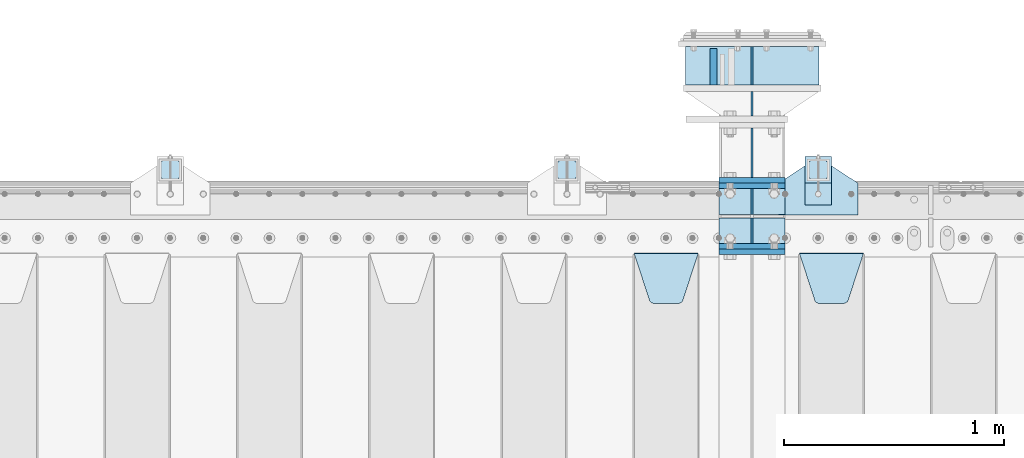
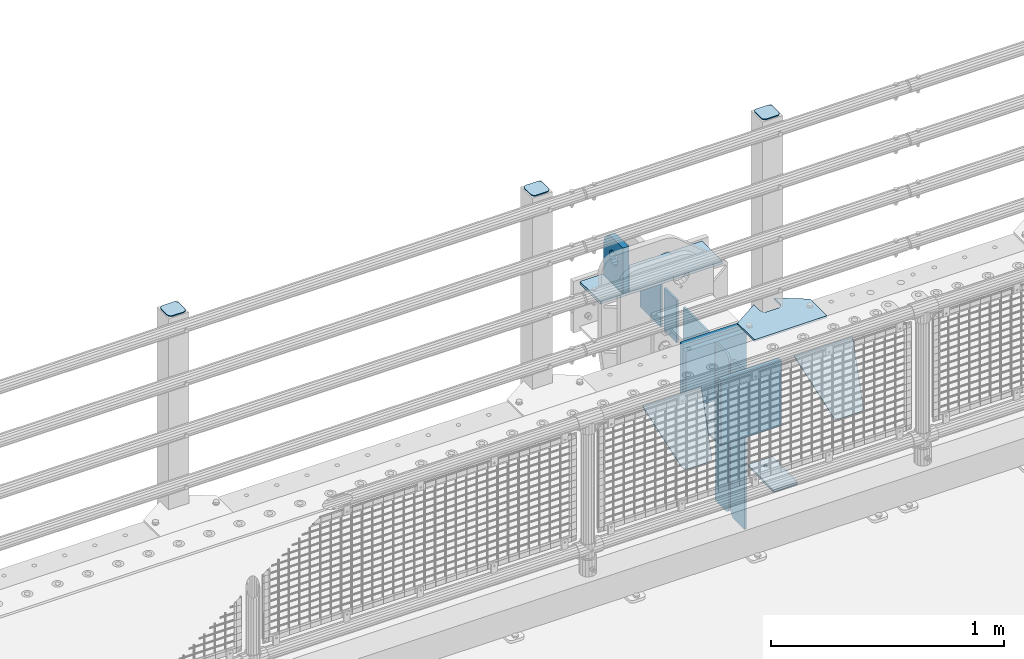
# One storey, part 200 of 219: 23 plates.
"""IFC2X3 building model written with IfcOpenShell, lengths in millimetres."""

from ifc_helpers import new_model, si_unit, frame, origin_with_axes, place, context, subcontext, project, spatial, faceted_brep, material, type_object, element, save


model = new_model("IFC2X3")

# Units and contexts
model_context = context("Model", 3, precision=1e-05, world=origin_with_axes())
body_context = subcontext(model_context, "Body", "Model", "MODEL_VIEW")
ifc_project = project(units=[si_unit("LENGTHUNIT", "METRE", prefix="MILLI"), si_unit("AREAUNIT", "SQUARE_METRE"), si_unit("VOLUMEUNIT", "CUBIC_METRE"), si_unit("MASSUNIT", "GRAM", prefix="KILO"), si_unit("TIMEUNIT", "SECOND"), si_unit("PLANEANGLEUNIT", "RADIAN"), si_unit("SOLIDANGLEUNIT", "STERADIAN"), si_unit("THERMODYNAMICTEMPERATUREUNIT", "DEGREE_CELSIUS"), si_unit("LUMINOUSINTENSITYUNIT", "LUMEN")], contexts=[model_context])

# Site, building, storey
site_placement = place(None, origin_with_axes())
site = spatial("IfcSite", under=ifc_project, at=site_placement, CompositionType="ELEMENT")
building_placement = place(site_placement, origin_with_axes())
building = spatial("IfcBuilding", under=site, at=building_placement, Name="Standard", CompositionType="ELEMENT")
storey_placement = place(building_placement, origin_with_axes())
storey = spatial("IfcBuildingStorey", under=building, at=storey_placement, Name="Undefined", CompositionType="ELEMENT", Elevation=0.0)

# Plates
ifc_material_1 = material(Name="STEEL/S355N")
plate_type_1 = type_object("IfcPlateType", PredefinedType="NOTDEFINED")
plate_1_placement = place(storey_placement, frame((10239.9999999781, 33162.4999999848, -340.000018238371), z_axis=(0.0, 0.0, 1.0), x_axis=(1.0, 0.0, 0.0)))
element("IfcPlate", 1, at=plate_1_placement, inside=storey, type_object=plate_type_1, material=ifc_material_1, context=body_context, shape_type="Brep", body=[
    faceted_brep([(0.0, -12.5, 0.0), (0.0, -12.5, 330.0), (0.0, 12.5, 330.0), (0.0, 12.5, 0.0), (300.0, -12.5, 330.0), (300.0, 12.5, 330.0), (300.0, -12.5, 0.0), (300.0, 12.5, 0.0)], [[[0, 1, 2, 3]], [[1, 4, 5, 2]], [[4, 6, 7, 5]], [[6, 0, 3, 7]], [[5, 7, 3, 2]], [[6, 4, 1, 0]]]),
])
plate_2_placement = place(storey_placement, frame((10240.0, 32837.5, -340.000000000044), z_axis=(0.0, 0.0, 1.0), x_axis=(1.0, 0.0, 0.0)))
element("IfcPlate", 2, at=plate_2_placement, inside=storey, type_object=plate_type_1, material=ifc_material_1, context=body_context, shape_type="Brep", body=[
    faceted_brep([(0.0, -12.5, 0.0), (9.27684595808387e-10, -12.5, 340.0), (9.27684595808387e-10, 12.5, 340.0), (0.0, 12.5, 0.0), (300.0, -12.5, 340.0), (300.0, 12.5, 340.0), (300.0, -12.5, 0.0), (300.0, 12.5, 0.0)], [[[0, 1, 2, 3]], [[1, 4, 5, 2]], [[4, 6, 7, 5]], [[6, 0, 3, 7]], [[5, 7, 3, 2]], [[6, 4, 1, 0]]]),
])
for number, where, z_axis, x_axis in (
    (3, (10240.0, 33137.5, -340.0), (0.0, 0.0, 1.0), (1.0, 0.0, 0.0)),
    (4, (10240.0, 32862.5, -340.0), (0.0, 0.0, 1.0), (1.0, 0.0, 0.0)),
):
    element("IfcPlate", number, at=place(storey_placement, frame(where, z_axis=z_axis, x_axis=x_axis)), inside=storey, type_object=plate_type_1, material=ifc_material_1, context=body_context, shape_type="Brep", body=[
        faceted_brep([(0.0, -12.5, 0.0), (0.0, -12.5, 310.0), (0.0, 12.5, 310.0), (0.0, 12.5, 0.0), (300.0, -12.5, 310.0), (300.0, 12.5, 310.0), (300.0, -12.5, 0.0), (300.0, 12.5, 0.0)], [[[0, 1, 2, 3]], [[1, 4, 5, 2]], [[4, 6, 7, 5]], [[6, 0, 3, 7]], [[5, 7, 3, 2]], [[6, 4, 1, 0]]]),
    ])
plate_type_2 = type_object("IfcPlateType", PredefinedType="NOTDEFINED")
plate_3_placement = place(storey_placement, frame((10389.9999999781, 33174.9999999848, -336.000018238371), z_axis=(0.0, 1.0, 0.0), x_axis=(0.0, 0.0, 1.0)))
element("IfcPlate", 5, at=plate_3_placement, inside=storey, type_object=plate_type_2, material=ifc_material_1, context=body_context, shape_type="Brep", body=[
    faceted_brep([(0.0, -5.0, 0.0), (100.0, -5.0, 225.0), (100.0, 5.0, 225.0), (0.0, 5.0, 0.0), (322.0, -5.0, 225.0), (322.0, 5.0, 225.0), (322.0, -5.0, 0.0), (322.0, 5.0, 0.0)], [[[0, 1, 2, 3]], [[1, 4, 5, 2]], [[4, 6, 7, 5]], [[6, 0, 3, 7]], [[5, 7, 3, 2]], [[6, 4, 1, 0]]]),
])
plate_type_3 = type_object("IfcPlateType", PredefinedType="NOTDEFINED")
plate_4_placement = place(storey_placement, frame((10214.4999999781, 33594.9999999848, -1.82383710125578e-05), z_axis=(0.0, 1.0, 0.0), x_axis=(0.0, 0.0, 1.0)))
element("IfcPlate", 6, at=plate_4_placement, inside=storey, type_object=plate_type_3, material=ifc_material_1, context=body_context, shape_type="Brep", body=[
    faceted_brep([(125.840713002492, 15.0, 114.183542702915), (125.840713002492, -15.0, 114.183542702915), (113.837049096098, -15.0, 106.162950903905), (113.837049096098, 15.0, 106.162950903905), (105.816457297082, -15.0, 94.1592869975066), (105.816457297082, 15.0, 94.1592869975066), (103.0, -15.0, 80.0), (103.0, 15.0, 80.0), (105.816457297082, -15.0, 65.8407130024934), (105.816457297082, 15.0, 65.8407130024934), (113.837049096098, -15.0, 53.8370490960951), (113.837049096098, 15.0, 53.8370490960951), (125.840713002492, -15.0, 45.8164572970854), (125.840713002492, 15.0, 45.8164572970854), (140.0, -15.0, 43.0), (140.0, 15.0, 43.0), (154.159286997508, -15.0, 45.8164572970854), (154.159286997508, 15.0, 45.8164572970854), (166.162950903902, -15.0, 53.8370490960951), (166.162950903902, 15.0, 53.8370490960951), (174.183542702918, -15.0, 65.8407130024934), (174.183542702918, 15.0, 65.8407130024934), (177.0, -15.0, 80.0), (177.0, 15.0, 80.0), (174.183542702918, -15.0, 94.1592869975066), (174.183542702918, 15.0, 94.1592869975066), (166.162950903902, -15.0, 106.162950903905), (166.162950903902, 15.0, 106.162950903905), (154.159286997508, -15.0, 114.183542702915), (154.159286997508, 15.0, 114.183542702915), (140.0, -15.0, 117.0), (140.0, 15.0, 117.0), (0.0, -15.0, 165.0), (170.0, -15.0, 165.0), (170.0, 15.0, 165.0), (0.0, 15.0, 165.0), (188.117333157176, -15.0, 162.614807840233), (188.117333157176, 15.0, 162.614807840233), (205.0, -15.0, 155.621778264911), (205.0, 15.0, 155.621778264911), (219.497474683058, -15.0, 144.497474683056), (219.497474683058, 15.0, 144.497474683056), (230.621778264911, -15.0, 130.0), (230.621778264911, 15.0, 130.0), (237.614807840235, -15.0, 113.117333157177), (237.614807840235, 15.0, 113.117333157177), (240.0, -15.0, 95.0), (240.0, 15.0, 95.0), (240.0, -15.0, 0.0), (240.0, 15.0, 0.0), (0.0, -15.0, 0.0), (0.0, 15.0, 0.0)], [[[0, 1, 2, 3]], [[3, 2, 4, 5]], [[5, 4, 6, 7]], [[7, 6, 8, 9]], [[9, 8, 10, 11]], [[11, 10, 12, 13]], [[13, 12, 14, 15]], [[15, 14, 16, 17]], [[17, 16, 18, 19]], [[19, 18, 20, 21]], [[21, 20, 22, 23]], [[23, 22, 24, 25]], [[25, 24, 26, 27]], [[27, 26, 28, 29]], [[29, 28, 30, 31]], [[31, 30, 1, 0]], [[32, 33, 34, 35]], [[33, 36, 37, 34]], [[36, 38, 39, 37]], [[38, 40, 41, 39]], [[40, 42, 43, 41]], [[42, 44, 45, 43]], [[44, 46, 47, 45]], [[46, 48, 49, 47]], [[48, 50, 51, 49]], [[34, 37, 39, 41, 43, 45, 47, 49, 51, 35], [3, 5, 7, 9, 11, 13, 15, 17, 19, 21, 23, 25, 27, 29, 31, 0]], [[50, 32, 35, 51]], [[48, 46, 44, 42, 40, 38, 36, 33, 32, 50], [26, 24, 22, 20, 18, 16, 14, 12, 10, 8, 6, 4, 2, 1, 30, 28]]]),
])
plate_type_4 = type_object("IfcPlateType", PredefinedType="NOTDEFINED")
for number, where, z_axis, x_axis in (
    (7, (10240.0, 32992.0, -343.0), (0.0, -1.0, 0.0), (1.0, 0.0, 0.0)),
    (8, (10240.0, 33008.0, -343.0), (0.0, 1.0, 0.0), (1.0, 0.0, 0.0)),
):
    element("IfcPlate", number, at=place(storey_placement, frame(where, z_axis=z_axis, x_axis=x_axis)), inside=storey, type_object=plate_type_4, material=ifc_material_1, context=body_context, shape_type="Brep", body=[
        faceted_brep([(0.0, -7.0, 0.0), (0.0, -7.0, 117.0), (0.0, 7.0, 117.0), (0.0, 7.0, 0.0), (300.0, -7.0, 117.0), (300.0, 7.0, 117.0), (300.0, -7.0, 0.0), (300.0, 7.0, 0.0)], [[[0, 1, 2, 3]], [[1, 4, 5, 2]], [[4, 6, 7, 5]], [[6, 0, 3, 7]], [[5, 7, 3, 2]], [[6, 4, 1, 0]]]),
    ])
plate_type_5 = type_object("IfcPlateType", PredefinedType="NOTDEFINED")
for number, where, z_axis, x_axis in (
    (9, (10390.0, 33008.0, -30.0), (0.0, 0.0, -1.0), (0.0, 1.0, 0.0)),
    (10, (10390.0, 32992.0, -30.0), (0.0, 0.0, -1.0), (0.0, -1.0, 0.0)),
):
    element("IfcPlate", number, at=place(storey_placement, frame(where, z_axis=z_axis, x_axis=x_axis)), inside=storey, type_object=plate_type_5, material=ifc_material_1, context=body_context, shape_type="Brep", body=[
        faceted_brep([(0.0, -5.0, 30.0), (0.0, -5.0, 306.0), (0.0, 5.0, 306.0), (0.0, 5.0, 30.0), (117.0, -5.0, 306.0), (117.0, 5.0, 306.0), (117.0, -5.0, 0.0), (117.0, 5.0, 0.0), (30.0, -5.0, 0.0), (30.0, 5.0, 0.0), (24.7905546699913, -5.0, 0.455767409633758), (24.7905546699913, 5.0, 0.455767409633758), (19.7393957002278, -5.0, 1.80922137642275), (19.7393957002278, 5.0, 1.80922137642275), (15.0, -5.0, 4.01923788646684), (15.0, 5.0, 4.01923788646684), (10.7163717094008, -5.0, 7.01866670643066), (10.7163717094008, 5.0, 7.01866670643066), (7.01866670643358, -5.0, 10.7163717094038), (7.01866670643358, 5.0, 10.7163717094038), (4.01923788646673, -5.0, 15.0), (4.01923788646673, 5.0, 15.0), (1.80922137642483, -5.0, 19.7393957002299), (1.80922137642483, 5.0, 19.7393957002299), (0.455767409635882, -5.0, 24.7905546699921), (0.455767409635882, 5.0, 24.7905546699921)], [[[0, 1, 2, 3]], [[1, 4, 5, 2]], [[4, 6, 7, 5]], [[6, 8, 9, 7]], [[8, 10, 11, 9]], [[10, 12, 13, 11]], [[12, 14, 15, 13]], [[14, 16, 17, 15]], [[16, 18, 19, 17]], [[18, 20, 21, 19]], [[20, 22, 23, 21]], [[22, 24, 25, 23]], [[24, 0, 3, 25]], [[5, 7, 9, 11, 13, 15, 17, 19, 21, 23, 25, 3, 2]], [[24, 22, 20, 18, 16, 14, 12, 10, 8, 6, 4, 1, 0]]]),
    ])
for number, where, z_axis, x_axis in (
    (11, (10390.0, 32992.0, -350.0), (0.0, 0.0, -1.0), (0.0, -1.0, 0.0)),
    (12, (10390.0, 33008.0, -350.0), (0.0, 0.0, -1.0), (0.0, 1.0, 0.0)),
):
    element("IfcPlate", number, at=place(storey_placement, frame(where, z_axis=z_axis, x_axis=x_axis)), inside=storey, type_object=plate_type_5, material=ifc_material_1, context=body_context, shape_type="Brep", body=[
        faceted_brep([(0.0, -5.0, 0.0), (0.0, -5.0, 480.0), (0.0, 5.0, 480.0), (0.0, 5.0, 0.0), (0.455767409635882, -5.0, 485.209445330008), (0.455767409635882, 5.0, 485.209445330008), (1.80922137642483, -5.0, 490.26060429977), (1.80922137642483, 5.0, 490.26060429977), (4.01923788646673, -5.0, 495.0), (4.01923788646673, 5.0, 495.0), (7.01866670643358, -5.0, 499.283628290596), (7.01866670643358, 5.0, 499.283628290596), (10.7163717094008, -5.0, 502.981333293569), (10.7163717094008, 5.0, 502.981333293569), (15.0, -5.0, 505.980762113533), (15.0, 5.0, 505.980762113533), (19.7393957002278, -5.0, 508.190778623577), (19.7393957002278, 5.0, 508.190778623577), (24.7905546699913, -5.0, 509.544232590366), (24.7905546699913, 5.0, 509.544232590366), (30.0, -5.0, 510.0), (30.0, 5.0, 510.0), (117.0, -5.0, 510.0), (117.0, 5.0, 510.0), (117.0, -5.0, 0.0), (117.0, 5.0, 0.0)], [[[0, 1, 2, 3]], [[1, 4, 5, 2]], [[4, 6, 7, 5]], [[6, 8, 9, 7]], [[8, 10, 11, 9]], [[10, 12, 13, 11]], [[12, 14, 15, 13]], [[14, 16, 17, 15]], [[16, 18, 19, 17]], [[18, 20, 21, 19]], [[20, 22, 23, 21]], [[22, 24, 25, 23]], [[24, 0, 3, 25]], [[5, 7, 9, 11, 13, 15, 17, 19, 21, 23, 25, 3, 2]], [[24, 22, 20, 18, 16, 14, 12, 10, 8, 6, 4, 1, 0]]]),
    ])
plate_type_6 = type_object("IfcPlateType", PredefinedType="NOTDEFINED")
plate_5_placement = place(storey_placement, frame((10605.0, 32831.767766956, -1.76776695296758), z_axis=(0.0, -0.707106781186547, -0.707106781186548), x_axis=(1.0, 0.0, 0.0)))
element("IfcPlate", 13, at=plate_5_placement, inside=storey, type_object=plate_type_6, material=ifc_material_1, context=body_context, shape_type="Brep", body=[
    faceted_brep([(0.0, -2.5, 0.0), (69.345504679477, -2.5, 300.171731424834), (69.345504679477, 2.49999999999636, 300.171731424831), (0.0, 2.5, 0.0), (70.9274061199576, -2.50000000000364, 304.8974424154), (70.9274061199576, 2.49999999999636, 304.8974424154), (73.3818627772307, -2.50000000000364, 309.234538108532), (73.3818627772307, 2.49999999999636, 309.234538108532), (76.6187032999569, -2.50000000000364, 313.023683126106), (76.6187032999569, 2.49999999999636, 313.023683126106), (80.5190132704993, -2.50000000000364, 316.125672595372), (80.5190132704993, 2.49999999999636, 316.125672595372), (84.9395038596831, -2.50000000000364, 318.426546230476), (84.9395038596831, 2.5, 318.426546230479), (89.7177759439237, -2.50000000000364, 319.841774983277), (89.7177759439237, 2.5, 319.841774983281), (94.6782862926502, -2.50000000000364, 320.319366455078), (94.6782862926502, 2.49999999999636, 320.319366455078), (195.32171370735, -2.50000000000364, 320.319366455078), (195.32171370735, 2.49999999999636, 320.319366455078), (200.282224056076, -2.50000000000364, 319.841774983277), (200.282224056076, 2.5, 319.841774983281), (205.060496140317, -2.50000000000364, 318.426546230476), (205.060496140317, 2.49999999999636, 318.426546230476), (209.480986729501, -2.50000000000364, 316.125672595372), (209.480986729501, 2.49999999999636, 316.125672595372), (213.381296700043, -2.50000000000364, 313.023683126106), (213.381296700043, 2.49999999999272, 313.023683126106), (216.618137222769, -2.50000000000364, 309.234538108529), (216.618137222769, 2.49999999999636, 309.234538108525), (219.072593880042, -2.50000000000364, 304.8974424154), (219.072593880042, 2.49999999999636, 304.8974424154), (220.654495320523, -2.5, 300.171731424834), (220.654495320523, 2.49999999999636, 300.171731424831), (290.0, -2.50000000000364, 3.63797880709171e-12), (290.0, 2.49999999999636, 0.0)], [[[0, 1, 2, 3]], [[1, 4, 5, 2]], [[4, 6, 7, 5]], [[6, 8, 9, 7]], [[8, 10, 11, 9]], [[10, 12, 13, 11]], [[12, 14, 15, 13]], [[14, 16, 17, 15]], [[16, 18, 19, 17]], [[18, 20, 21, 19]], [[20, 22, 23, 21]], [[22, 24, 25, 23]], [[24, 26, 27, 25]], [[26, 28, 29, 27]], [[28, 30, 31, 29]], [[30, 32, 33, 31]], [[32, 34, 35, 33]], [[34, 0, 3, 35]], [[5, 7, 9, 11, 13, 15, 17, 19, 21, 23, 25, 27, 29, 31, 33, 35, 3, 2]], [[34, 32, 30, 28, 26, 24, 22, 20, 18, 16, 14, 12, 10, 8, 6, 4, 1, 0]]]),
])
plate_6_placement = place(storey_placement, frame((9855.0, 32831.767766956, -1.76776695296758), z_axis=(0.0, -0.707106781186547, -0.707106781186548), x_axis=(1.0, 0.0, 0.0)))
element("IfcPlate", 14, at=plate_6_placement, inside=storey, type_object=plate_type_6, material=ifc_material_1, context=body_context, shape_type="Brep", body=[
    faceted_brep([(0.0, -2.5, 0.0), (69.345504679477, -2.5, 300.171731424834), (69.345504679477, 2.49999999999636, 300.171731424831), (0.0, 2.5, 0.0), (70.9274061199576, -2.50000000000364, 304.8974424154), (70.9274061199576, 2.49999999999636, 304.8974424154), (73.3818627772307, -2.50000000000364, 309.234538108532), (73.3818627772307, 2.49999999999636, 309.234538108532), (76.6187032999569, -2.50000000000364, 313.023683126106), (76.6187032999569, 2.49999999999636, 313.023683126106), (80.5190132704993, -2.50000000000364, 316.125672595372), (80.5190132704993, 2.49999999999636, 316.125672595372), (84.9395038596831, -2.50000000000364, 318.426546230476), (84.9395038596831, 2.5, 318.426546230479), (89.7177759439237, -2.50000000000364, 319.841774983277), (89.7177759439237, 2.5, 319.841774983281), (94.6782862926502, -2.50000000000364, 320.319366455078), (94.6782862926502, 2.49999999999636, 320.319366455078), (195.32171370735, -2.50000000000364, 320.319366455078), (195.32171370735, 2.49999999999636, 320.319366455078), (200.282224056076, -2.50000000000364, 319.841774983277), (200.282224056076, 2.5, 319.841774983281), (205.060496140317, -2.50000000000364, 318.426546230476), (205.060496140317, 2.49999999999636, 318.426546230476), (209.480986729501, -2.50000000000364, 316.125672595372), (209.480986729501, 2.49999999999636, 316.125672595372), (213.381296700043, -2.50000000000364, 313.023683126106), (213.381296700043, 2.49999999999272, 313.023683126106), (216.618137222769, -2.50000000000364, 309.234538108529), (216.618137222769, 2.49999999999636, 309.234538108525), (219.072593880042, -2.50000000000364, 304.8974424154), (219.072593880042, 2.49999999999636, 304.8974424154), (220.654495320523, -2.5, 300.171731424834), (220.654495320523, 2.49999999999636, 300.171731424831), (290.0, -2.50000000000364, 3.63797880709171e-12), (290.0, 2.49999999999636, 0.0)], [[[0, 1, 2, 3]], [[1, 4, 5, 2]], [[4, 6, 7, 5]], [[6, 8, 9, 7]], [[8, 10, 11, 9]], [[10, 12, 13, 11]], [[12, 14, 15, 13]], [[14, 16, 17, 15]], [[16, 18, 19, 17]], [[18, 20, 21, 19]], [[20, 22, 23, 21]], [[22, 24, 25, 23]], [[24, 26, 27, 25]], [[26, 28, 29, 27]], [[28, 30, 31, 29]], [[30, 32, 33, 31]], [[32, 34, 35, 33]], [[34, 0, 3, 35]], [[5, 7, 9, 11, 13, 15, 17, 19, 21, 23, 25, 27, 29, 31, 33, 35, 3, 2]], [[34, 32, 30, 28, 26, 24, 22, 20, 18, 16, 14, 12, 10, 8, 6, 4, 1, 0]]]),
])
ifc_material_2 = material(Name="STEEL/S355J2")
plate_type_7 = type_object("IfcPlateType", PredefinedType="NOTDEFINED")
plate_7_placement = place(storey_placement, frame((10510.0, 33005.0, 5.00000000004911), z_axis=(0.0, 1.0, 0.0), x_axis=(1.0, 0.0, 0.0)))
element("IfcPlate", 15, at=plate_7_placement, inside=storey, type_object=plate_type_7, material=ifc_material_2, context=body_context, shape_type="Brep", body=[
    faceted_brep([(0.0, -5.0, 0.0), (2.31396552408114e-06, -5.0, 145.0), (2.31396552408114e-06, 5.0, 145.0), (0.0, 5.0, 0.0), (130.0, -5.0, 230.0), (130.0, 5.0, 230.0), (130.0, -5.0, 180.0), (130.0, 5.0, 180.0), (130.48036798992, -5.0, 175.122741949599), (130.48036798992, 5.0, 175.122741949599), (131.903011687218, -5.0, 170.432914190875), (131.903011687218, 5.0, 170.432914190875), (134.213259692437, -5.0, 166.110744174512), (134.213259692437, 5.0, 166.110744174512), (137.322330470337, -5.0, 162.322330470335), (137.322330470337, 5.0, 162.322330470335), (141.11074417451, -5.0, 159.213259692435), (141.11074417451, 5.0, 159.213259692435), (145.432914190873, -5.0, 156.903011687216), (145.432914190873, 5.0, 156.903011687216), (150.122741949597, -5.0, 155.48036798992), (150.122741949597, 5.0, 155.48036798992), (155.0, -5.0, 155.0), (155.0, 5.0, 155.0), (205.0, -5.0, 155.0), (205.0, 5.0, 155.0), (209.877258050403, -5.0, 155.48036798992), (209.877258050403, 5.0, 155.48036798992), (214.567085809127, -5.0, 156.903011687216), (214.567085809127, 5.0, 156.903011687216), (218.88925582549, -5.0, 159.213259692435), (218.88925582549, 5.0, 159.213259692435), (222.677669529663, -5.0, 162.322330470335), (222.677669529663, 5.0, 162.322330470335), (225.786740307563, -5.0, 166.110744174512), (225.786740307563, 5.0, 166.110744174512), (228.096988312782, -5.0, 170.432914190875), (228.096988312782, 5.0, 170.432914190875), (229.51963201008, -5.0, 175.122741949599), (229.51963201008, 5.0, 175.122741949599), (230.0, -5.0, 180.0), (230.0, 5.0, 180.0), (230.0, -5.0, 230.0), (230.0, 5.0, 230.0), (360.0, -5.0, 145.0), (360.0, 5.0, 145.0), (360.0, -5.0, -7.27595761418343e-12), (360.0, 5.0, -7.27595761418343e-12)], [[[0, 1, 2, 3]], [[1, 4, 5, 2]], [[4, 6, 7, 5]], [[6, 8, 9, 7]], [[8, 10, 11, 9]], [[10, 12, 13, 11]], [[12, 14, 15, 13]], [[14, 16, 17, 15]], [[16, 18, 19, 17]], [[18, 20, 21, 19]], [[20, 22, 23, 21]], [[22, 24, 25, 23]], [[24, 26, 27, 25]], [[26, 28, 29, 27]], [[28, 30, 31, 29]], [[30, 32, 33, 31]], [[32, 34, 35, 33]], [[34, 36, 37, 35]], [[36, 38, 39, 37]], [[38, 40, 41, 39]], [[40, 42, 43, 41]], [[42, 44, 45, 43]], [[44, 46, 47, 45]], [[46, 0, 3, 47]], [[5, 7, 9, 11, 13, 15, 17, 19, 21, 23, 25, 27, 29, 31, 33, 35, 37, 39, 41, 43, 45, 47, 3, 2]], [[46, 44, 42, 40, 38, 36, 34, 32, 30, 28, 26, 24, 22, 20, 18, 16, 14, 12, 10, 8, 6, 4, 1, 0]]]),
])
plate_type_8 = type_object("IfcPlateType", PredefinedType="NOTDEFINED")
plate_8_placement = place(storey_placement, frame((10630.0000000001, 33050.0000000002, -850.000000000002), z_axis=(0.0, 1.0, 0.0), x_axis=(1.0, 0.0, 0.0)))
element("IfcPlate", 16, at=plate_8_placement, inside=storey, type_object=plate_type_8, material=ifc_material_2, context=body_context, shape_type="Brep", body=[
    faceted_brep([(66.3639610305399, -5.0, 163.636038969111), (66.3639610305399, 5.0, 163.636038969111), (59.9999999998618, 5.0, 160.999999999789), (59.9999999998618, -5.0, 160.999999999789), (53.6360389691836, 5.0, 163.636038969111), (53.6360389691836, -5.0, 163.636038969111), (50.9999999998618, 5.0, 169.999999999789), (50.9999999998618, -5.0, 169.999999999789), (53.6360389691836, 5.0, 176.363961030467), (53.6360389691836, -5.0, 176.363961030467), (59.9999999998618, 5.0, 178.999999999789), (59.9999999998618, -5.0, 178.999999999789), (66.3639610305399, 5.0, 176.363961030467), (66.3639610305399, -5.0, 176.363961030467), (68.9999999998618, 5.0, 169.999999999789), (68.9999999998618, -5.0, 169.999999999789), (120.0, -5.0, 0.0), (120.0, -5.0, 220.0), (0.0, -5.0, 220.0), (0.0, -5.0, 0.0), (0.0, 5.0, 0.0), (120.0, 5.0, 0.0), (120.0, 5.0, 220.0), (0.0, 5.0, 220.0)], [[[0, 1, 2, 3]], [[3, 2, 4, 5]], [[5, 4, 6, 7]], [[7, 6, 8, 9]], [[9, 8, 10, 11]], [[11, 10, 12, 13]], [[13, 12, 14, 15]], [[15, 14, 1, 0]], [[16, 17, 18, 19], [3, 5, 7, 9, 11, 13, 15, 0]], [[16, 19, 20, 21]], [[17, 16, 21, 22]], [[18, 17, 22, 23]], [[19, 18, 23, 20]], [[22, 21, 20, 23], [10, 8, 6, 4, 2, 1, 14, 12]]]),
])
plate_type_9 = type_object("IfcPlateType", PredefinedType="NOTDEFINED")
plate_9_placement = place(storey_placement, frame((10734.0000000001, 33166.0000000002, 1012.50000000001), z_axis=(0.0, 1.0, 0.0), x_axis=(-1.0, 0.0, 0.0)))
element("IfcPlate", 17, at=plate_9_placement, inside=storey, type_object=plate_type_9, material=ifc_material_2, context=body_context, shape_type="Brep", body=[
    faceted_brep([(0.0, -2.5, 19.0), (0.0, -2.5, 69.0), (0.0, 2.5, 69.0), (0.0, 2.5, 19.0), (0.476369668545885, -2.5, 73.2278977451715), (0.476369668545885, 2.5, 73.2278977451715), (1.88159150985484, -2.5, 77.2437910432345), (1.88159150985484, 2.5, 77.2437910432345), (4.14520183310742, -2.5, 80.8463062353185), (4.14520183310742, 2.5, 80.8463062353185), (7.15369376468334, -2.5, 83.8547981668889), (7.15369376468334, 2.5, 83.8547981668889), (10.7562089567673, -2.5, 86.118408490147), (10.7562089567673, 2.5, 86.118408490147), (14.7721022548303, -2.5, 87.5236303314523), (14.7721022548303, 2.5, 87.5236303314523), (19.0, -2.5, 88.0), (19.0, 2.5, 88.0), (69.0, -2.5, 88.0), (69.0, 2.5, 88.0), (73.2278977451697, -2.5, 87.5236303314523), (73.2278977451697, 2.5, 87.5236303314523), (77.2437910432327, -2.5, 86.118408490147), (77.2437910432327, 2.5, 86.118408490147), (80.8463062353167, -2.5, 83.8547981668889), (80.8463062353167, 2.5, 83.8547981668889), (83.8547981668926, -2.5, 80.8463062353185), (83.8547981668926, 2.5, 80.8463062353185), (86.1184084901452, -2.5, 77.2437910432345), (86.1184084901452, 2.5, 77.2437910432345), (87.5236303314541, -2.5, 73.2278977451715), (87.5236303314541, 2.5, 73.2278977451715), (88.0, -2.5, 69.0), (88.0, 2.5, 69.0), (88.0, -2.5, 19.0), (88.0, 2.5, 19.0), (87.5236303314541, -2.5, 14.7721022548285), (87.5236303314541, 2.5, 14.7721022548285), (86.1184084901452, -2.5, 10.7562089567655), (86.1184084901452, 2.5, 10.7562089567655), (83.8547981668926, -2.5, 7.15369376468152), (83.8547981668926, 2.5, 7.15369376468152), (80.8463062353167, -2.5, 4.14520183311106), (80.8463062353167, 2.5, 4.14520183311106), (77.2437910432345, -2.5, 1.88159150985302), (77.2437910432345, 2.5, 1.88159150985302), (73.2278977451697, -2.5, 0.476369668547704), (73.2278977451697, 2.5, 0.476369668547704), (69.0, -2.5, 0.0), (69.0, 2.5, 0.0), (19.0, -2.5, 0.0), (19.0, 2.5, 0.0), (14.7721022548303, -2.5, 0.476369668547704), (14.7721022548303, 2.5, 0.476369668547704), (10.7562089567673, -2.5, 1.88159150985302), (10.7562089567673, 2.5, 1.88159150985302), (7.15369376468334, -2.5, 4.14520183311106), (7.15369376468334, 2.5, 4.14520183311106), (4.14520183310742, -2.5, 7.15369376468152), (4.14520183310742, 2.5, 7.15369376468152), (1.88159150985484, -2.5, 10.7562089567655), (1.88159150985484, 2.5, 10.7562089567655), (0.476369668545885, -2.5, 14.7721022548285), (0.476369668545885, 2.5, 14.7721022548285)], [[[0, 1, 2, 3]], [[1, 4, 5, 2]], [[4, 6, 7, 5]], [[6, 8, 9, 7]], [[8, 10, 11, 9]], [[10, 12, 13, 11]], [[12, 14, 15, 13]], [[14, 16, 17, 15]], [[16, 18, 19, 17]], [[18, 20, 21, 19]], [[20, 22, 23, 21]], [[22, 24, 25, 23]], [[24, 26, 27, 25]], [[26, 28, 29, 27]], [[28, 30, 31, 29]], [[30, 32, 33, 31]], [[32, 34, 35, 33]], [[34, 36, 37, 35]], [[36, 38, 39, 37]], [[38, 40, 41, 39]], [[40, 42, 43, 41]], [[42, 44, 45, 43]], [[44, 46, 47, 45]], [[46, 48, 49, 47]], [[48, 50, 51, 49]], [[50, 52, 53, 51]], [[52, 54, 55, 53]], [[54, 56, 57, 55]], [[56, 58, 59, 57]], [[58, 60, 61, 59]], [[60, 62, 63, 61]], [[62, 0, 3, 63]], [[5, 7, 9, 11, 13, 15, 17, 19, 21, 23, 25, 27, 29, 31, 33, 35, 37, 39, 41, 43, 45, 47, 49, 51, 53, 55, 57, 59, 61, 63, 3, 2]], [[62, 60, 58, 56, 54, 52, 50, 48, 46, 44, 42, 40, 38, 36, 34, 32, 30, 28, 26, 24, 22, 20, 18, 16, 14, 12, 10, 8, 6, 4, 1, 0]]]),
])
plate_10_placement = place(storey_placement, frame((9594.00000000013, 33166.0000000002, 1012.50000000001), z_axis=(0.0, 1.0, 0.0), x_axis=(-1.0, 0.0, 0.0)))
element("IfcPlate", 18, at=plate_10_placement, inside=storey, type_object=plate_type_9, material=ifc_material_2, context=body_context, shape_type="Brep", body=[
    faceted_brep([(0.0, -2.5, 19.0), (0.0, -2.5, 69.0), (0.0, 2.5, 69.0), (0.0, 2.5, 19.0), (0.476369668545885, -2.5, 73.2278977451715), (0.476369668545885, 2.5, 73.2278977451715), (1.88159150985484, -2.5, 77.2437910432345), (1.88159150985484, 2.5, 77.2437910432345), (4.14520183310742, -2.5, 80.8463062353185), (4.14520183310742, 2.5, 80.8463062353185), (7.15369376468334, -2.5, 83.8547981668889), (7.15369376468334, 2.5, 83.8547981668889), (10.7562089567673, -2.5, 86.118408490147), (10.7562089567673, 2.5, 86.118408490147), (14.7721022548303, -2.5, 87.5236303314523), (14.7721022548303, 2.5, 87.5236303314523), (19.0, -2.5, 88.0), (19.0, 2.5, 88.0), (69.0, -2.5, 88.0), (69.0, 2.5, 88.0), (73.2278977451697, -2.5, 87.5236303314523), (73.2278977451697, 2.5, 87.5236303314523), (77.2437910432327, -2.5, 86.118408490147), (77.2437910432327, 2.5, 86.118408490147), (80.8463062353167, -2.5, 83.8547981668889), (80.8463062353167, 2.5, 83.8547981668889), (83.8547981668926, -2.5, 80.8463062353185), (83.8547981668926, 2.5, 80.8463062353185), (86.1184084901452, -2.5, 77.2437910432345), (86.1184084901452, 2.5, 77.2437910432345), (87.5236303314541, -2.5, 73.2278977451715), (87.5236303314541, 2.5, 73.2278977451715), (88.0, -2.5, 69.0), (88.0, 2.5, 69.0), (88.0, -2.5, 19.0), (88.0, 2.5, 19.0), (87.5236303314541, -2.5, 14.7721022548285), (87.5236303314541, 2.5, 14.7721022548285), (86.1184084901452, -2.5, 10.7562089567655), (86.1184084901452, 2.5, 10.7562089567655), (83.8547981668926, -2.5, 7.15369376468152), (83.8547981668926, 2.5, 7.15369376468152), (80.8463062353167, -2.5, 4.14520183311106), (80.8463062353167, 2.5, 4.14520183311106), (77.2437910432345, -2.5, 1.88159150985302), (77.2437910432345, 2.5, 1.88159150985302), (73.2278977451697, -2.5, 0.476369668547704), (73.2278977451697, 2.5, 0.476369668547704), (69.0, -2.5, 0.0), (69.0, 2.5, 0.0), (19.0, -2.5, 0.0), (19.0, 2.5, 0.0), (14.7721022548303, -2.5, 0.476369668547704), (14.7721022548303, 2.5, 0.476369668547704), (10.7562089567673, -2.5, 1.88159150985302), (10.7562089567673, 2.5, 1.88159150985302), (7.15369376468334, -2.5, 4.14520183311106), (7.15369376468334, 2.5, 4.14520183311106), (4.14520183310742, -2.5, 7.15369376468152), (4.14520183310742, 2.5, 7.15369376468152), (1.88159150985484, -2.5, 10.7562089567655), (1.88159150985484, 2.5, 10.7562089567655), (0.476369668545885, -2.5, 14.7721022548285), (0.476369668545885, 2.5, 14.7721022548285)], [[[0, 1, 2, 3]], [[1, 4, 5, 2]], [[4, 6, 7, 5]], [[6, 8, 9, 7]], [[8, 10, 11, 9]], [[10, 12, 13, 11]], [[12, 14, 15, 13]], [[14, 16, 17, 15]], [[16, 18, 19, 17]], [[18, 20, 21, 19]], [[20, 22, 23, 21]], [[22, 24, 25, 23]], [[24, 26, 27, 25]], [[26, 28, 29, 27]], [[28, 30, 31, 29]], [[30, 32, 33, 31]], [[32, 34, 35, 33]], [[34, 36, 37, 35]], [[36, 38, 39, 37]], [[38, 40, 41, 39]], [[40, 42, 43, 41]], [[42, 44, 45, 43]], [[44, 46, 47, 45]], [[46, 48, 49, 47]], [[48, 50, 51, 49]], [[50, 52, 53, 51]], [[52, 54, 55, 53]], [[54, 56, 57, 55]], [[56, 58, 59, 57]], [[58, 60, 61, 59]], [[60, 62, 63, 61]], [[62, 0, 3, 63]], [[5, 7, 9, 11, 13, 15, 17, 19, 21, 23, 25, 27, 29, 31, 33, 35, 37, 39, 41, 43, 45, 47, 49, 51, 53, 55, 57, 59, 61, 63, 3, 2]], [[62, 60, 58, 56, 54, 52, 50, 48, 46, 44, 42, 40, 38, 36, 34, 32, 30, 28, 26, 24, 22, 20, 18, 16, 14, 12, 10, 8, 6, 4, 1, 0]]]),
])
plate_11_placement = place(storey_placement, frame((7794.00000000013, 33166.0000000002, 1012.50000000001), z_axis=(0.0, 1.0, 0.0), x_axis=(-1.0, 0.0, 0.0)))
element("IfcPlate", 19, at=plate_11_placement, inside=storey, type_object=plate_type_9, material=ifc_material_2, context=body_context, shape_type="Brep", body=[
    faceted_brep([(0.0, -2.5, 19.0), (0.0, -2.5, 69.0), (0.0, 2.5, 69.0), (0.0, 2.5, 19.0), (0.476369668545885, -2.5, 73.2278977451715), (0.476369668545885, 2.5, 73.2278977451715), (1.88159150985484, -2.5, 77.2437910432345), (1.88159150985484, 2.5, 77.2437910432345), (4.14520183310742, -2.5, 80.8463062353185), (4.14520183310742, 2.5, 80.8463062353185), (7.15369376468334, -2.5, 83.8547981668889), (7.15369376468334, 2.5, 83.8547981668889), (10.7562089567673, -2.5, 86.118408490147), (10.7562089567673, 2.5, 86.118408490147), (14.7721022548303, -2.5, 87.5236303314523), (14.7721022548303, 2.5, 87.5236303314523), (19.0, -2.5, 88.0), (19.0, 2.5, 88.0), (69.0, -2.5, 88.0), (69.0, 2.5, 88.0), (73.2278977451697, -2.5, 87.5236303314523), (73.2278977451697, 2.5, 87.5236303314523), (77.2437910432327, -2.5, 86.118408490147), (77.2437910432327, 2.5, 86.118408490147), (80.8463062353167, -2.5, 83.8547981668889), (80.8463062353167, 2.5, 83.8547981668889), (83.8547981668926, -2.5, 80.8463062353185), (83.8547981668926, 2.5, 80.8463062353185), (86.1184084901452, -2.5, 77.2437910432345), (86.1184084901452, 2.5, 77.2437910432345), (87.5236303314541, -2.5, 73.2278977451715), (87.5236303314541, 2.5, 73.2278977451715), (88.0, -2.5, 69.0), (88.0, 2.5, 69.0), (88.0, -2.5, 19.0), (88.0, 2.5, 19.0), (87.5236303314541, -2.5, 14.7721022548285), (87.5236303314541, 2.5, 14.7721022548285), (86.1184084901452, -2.5, 10.7562089567655), (86.1184084901452, 2.5, 10.7562089567655), (83.8547981668926, -2.5, 7.15369376468152), (83.8547981668926, 2.5, 7.15369376468152), (80.8463062353167, -2.5, 4.14520183311106), (80.8463062353167, 2.5, 4.14520183311106), (77.2437910432345, -2.5, 1.88159150985302), (77.2437910432345, 2.5, 1.88159150985302), (73.2278977451697, -2.5, 0.476369668547704), (73.2278977451697, 2.5, 0.476369668547704), (69.0, -2.5, 0.0), (69.0, 2.5, 0.0), (19.0, -2.5, 0.0), (19.0, 2.5, 0.0), (14.7721022548303, -2.5, 0.476369668547704), (14.7721022548303, 2.5, 0.476369668547704), (10.7562089567673, -2.5, 1.88159150985302), (10.7562089567673, 2.5, 1.88159150985302), (7.15369376468334, -2.5, 4.14520183311106), (7.15369376468334, 2.5, 4.14520183311106), (4.14520183310742, -2.5, 7.15369376468152), (4.14520183310742, 2.5, 7.15369376468152), (1.88159150985484, -2.5, 10.7562089567655), (1.88159150985484, 2.5, 10.7562089567655), (0.476369668545885, -2.5, 14.7721022548285), (0.476369668545885, 2.5, 14.7721022548285)], [[[0, 1, 2, 3]], [[1, 4, 5, 2]], [[4, 6, 7, 5]], [[6, 8, 9, 7]], [[8, 10, 11, 9]], [[10, 12, 13, 11]], [[12, 14, 15, 13]], [[14, 16, 17, 15]], [[16, 18, 19, 17]], [[18, 20, 21, 19]], [[20, 22, 23, 21]], [[22, 24, 25, 23]], [[24, 26, 27, 25]], [[26, 28, 29, 27]], [[28, 30, 31, 29]], [[30, 32, 33, 31]], [[32, 34, 35, 33]], [[34, 36, 37, 35]], [[36, 38, 39, 37]], [[38, 40, 41, 39]], [[40, 42, 43, 41]], [[42, 44, 45, 43]], [[44, 46, 47, 45]], [[46, 48, 49, 47]], [[48, 50, 51, 49]], [[50, 52, 53, 51]], [[52, 54, 55, 53]], [[54, 56, 57, 55]], [[56, 58, 59, 57]], [[58, 60, 61, 59]], [[60, 62, 63, 61]], [[62, 0, 3, 63]], [[5, 7, 9, 11, 13, 15, 17, 19, 21, 23, 25, 27, 29, 31, 33, 35, 37, 39, 41, 43, 45, 47, 49, 51, 53, 55, 57, 59, 61, 63, 3, 2]], [[62, 60, 58, 56, 54, 52, 50, 48, 46, 44, 42, 40, 38, 36, 34, 32, 30, 28, 26, 24, 22, 20, 18, 16, 14, 12, 10, 8, 6, 4, 1, 0]]]),
])
plate_type_10 = type_object("IfcPlateType", PredefinedType="NOTDEFINED")
plate_12_placement = place(storey_placement, frame((10630.0000000001, 33050.0000000002, -857.500000000002), z_axis=(0.0, 1.0, 0.0), x_axis=(1.0, 0.0, 0.0)))
element("IfcPlate", 20, at=plate_12_placement, inside=storey, type_object=plate_type_10, material=ifc_material_2, context=body_context, shape_type="Brep", body=[
    faceted_brep([(0.0, -2.5, 0.0), (0.0, -2.5, 100.0), (0.0, 2.5, 100.0), (0.0, 2.5, 0.0), (120.0, -2.5, 100.0), (120.0, 2.5, 100.0), (120.0, -2.5, 0.0), (120.0, 2.5, 0.0)], [[[0, 1, 2, 3]], [[1, 4, 5, 2]], [[4, 6, 7, 5]], [[6, 0, 3, 7]], [[5, 7, 3, 2]], [[6, 4, 1, 0]]]),
])
plate_type_11 = type_object("IfcPlateType", PredefinedType="NOTDEFINED")
plate_13_placement = place(storey_placement, frame((10389.9999999781, 33769.9999999848, -14.000018238371), z_axis=(0.0, 0.0, -1.0), x_axis=(0.0, -1.0, 0.0)))
element("IfcPlate", 21, at=plate_13_placement, inside=storey, type_object=plate_type_11, material=ifc_material_1, context=body_context, shape_type="Brep", body=[
    faceted_brep([(0.0, -5.0, 0.0), (0.0, -5.0, 222.0), (0.0, 5.0, 222.0), (0.0, 5.0, 0.0), (175.0, -5.0, 222.0), (175.0, 5.0, 222.0), (175.0, -5.0, 0.0), (175.0, 5.0, 0.0)], [[[0, 1, 2, 3]], [[1, 4, 5, 2]], [[4, 6, 7, 5]], [[6, 0, 3, 7]], [[5, 7, 3, 2]], [[6, 4, 1, 0]]]),
])
plate_type_12 = type_object("IfcPlateType", PredefinedType="NOTDEFINED")
plate_14_placement = place(storey_placement, frame((10389.9999999781, 33564.9999999848, -14.000018238371), z_axis=(0.0, 0.0, -1.0), x_axis=(0.0, -1.0, 0.0)))
element("IfcPlate", 22, at=plate_14_placement, inside=storey, type_object=plate_type_12, material=ifc_material_1, context=body_context, shape_type="Brep", body=[
    faceted_brep([(0.0, -5.0, 0.0), (0.0, -5.0, 222.0), (0.0, 5.0, 222.0), (0.0, 5.0, 0.0), (110.0, -5.0, 222.0), (110.0, 5.0, 222.0), (110.0, -5.0, 0.0), (110.0, 5.0, 0.0)], [[[0, 1, 2, 3]], [[1, 4, 5, 2]], [[4, 6, 7, 5]], [[6, 0, 3, 7]], [[5, 7, 3, 2]], [[6, 4, 1, 0]]]),
])
ifc_material_3 = material()
plate_type_13 = type_object("IfcPlateType", PredefinedType="NOTDEFINED")
plate_15_placement = place(storey_placement, frame((10692.4999999781, 33594.9999999848, -7.00001823837101), z_axis=(0.0, 1.0, 0.0), x_axis=(-1.0, 0.0, 0.0)))
element("IfcPlate", 23, at=plate_15_placement, inside=storey, type_object=plate_type_13, material=ifc_material_3, context=body_context, shape_type="Brep", body=[
    faceted_brep([(0.0, -7.0, 0.0), (0.0, -7.0, 175.0), (0.0, 7.0, 175.0), (0.0, 7.0, 0.0), (605.0, -7.0, 175.0), (605.0, 7.0, 175.0), (605.0, -7.0, 0.0), (605.0, 7.0, 0.0)], [[[0, 1, 2, 3]], [[1, 4, 5, 2]], [[4, 6, 7, 5]], [[6, 0, 3, 7]], [[5, 7, 3, 2]], [[6, 4, 1, 0]]]),
])

save(model, "model.ifc")
